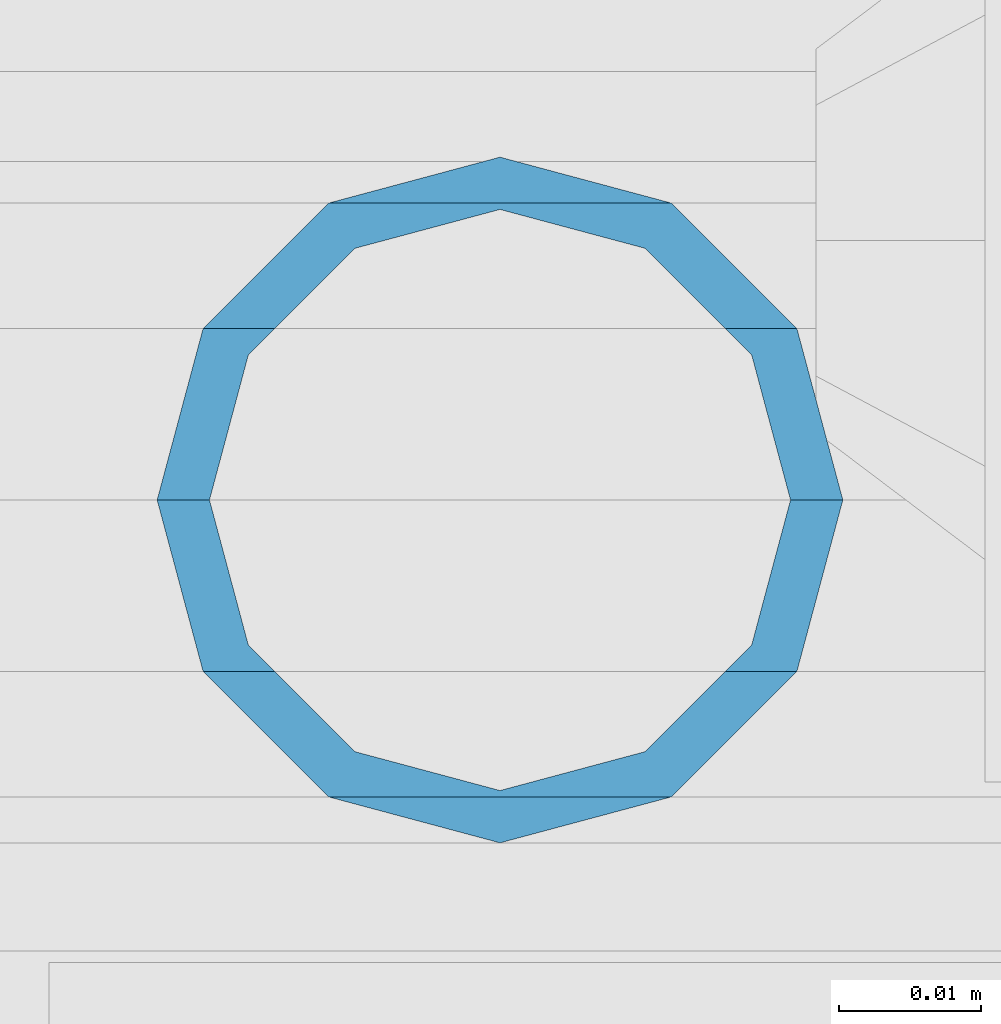
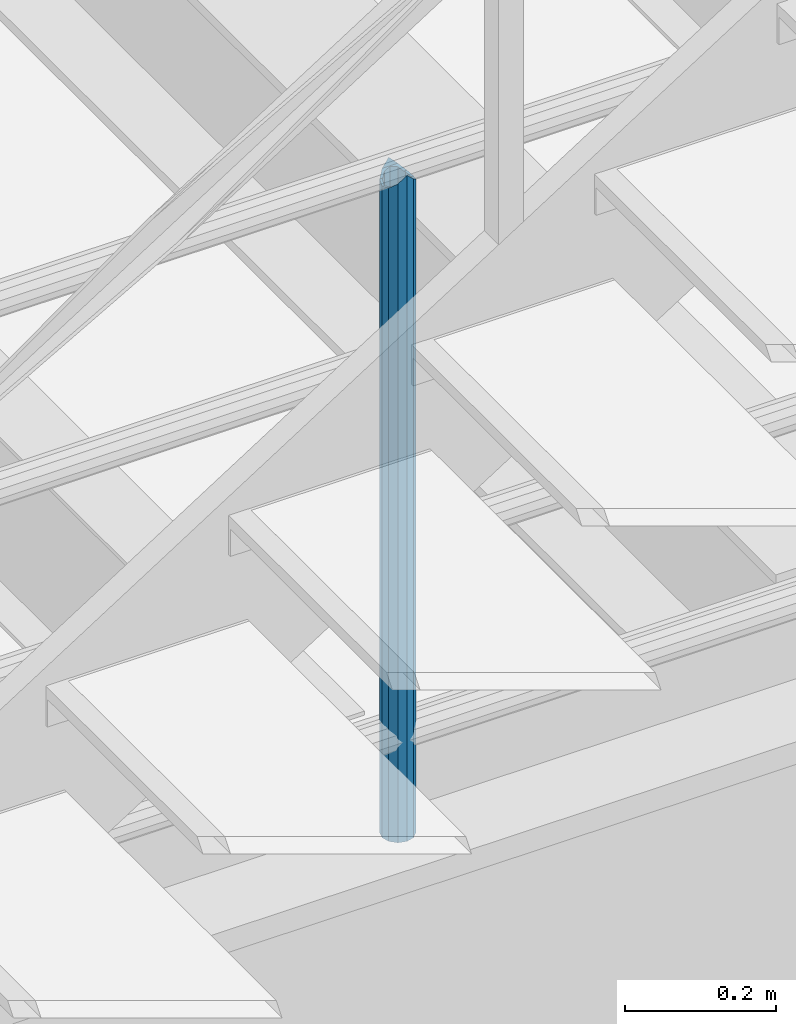
# One storey, part 614 of 1876: 1 column, 1 element without a shape of its own.
"""IFC2X3 building model written with IfcOpenShell, lengths in millimetres."""

from ifc_helpers import new_model, si_unit, frame, origin_with_axes, place, context, subcontext, project, spatial, faceted_brep, material, type_object, element, aggregate, save


model = new_model("IFC2X3")

# Units and contexts
model_context = context("Model", 3, precision=1e-05, world=origin_with_axes())
body_context = subcontext(model_context, "Body", "Model", "MODEL_VIEW")
ifc_project = project(units=[si_unit("LENGTHUNIT", "METRE", prefix="MILLI"), si_unit("AREAUNIT", "SQUARE_METRE"), si_unit("VOLUMEUNIT", "CUBIC_METRE"), si_unit("MASSUNIT", "GRAM", prefix="KILO"), si_unit("TIMEUNIT", "SECOND"), si_unit("PLANEANGLEUNIT", "RADIAN"), si_unit("SOLIDANGLEUNIT", "STERADIAN"), si_unit("THERMODYNAMICTEMPERATUREUNIT", "DEGREE_CELSIUS"), si_unit("LUMINOUSINTENSITYUNIT", "LUMEN")], contexts=[model_context])

# Site, building, storey
site_placement = place(None, origin_with_axes())
site = spatial("IfcSite", under=ifc_project, at=site_placement, CompositionType="ELEMENT")
building_placement = place(site_placement, origin_with_axes())
building = spatial("IfcBuilding", under=site, at=building_placement, Name="Undefined", CompositionType="ELEMENT")
storey_placement = place(building_placement, origin_with_axes())
storey = spatial("IfcBuildingStorey", under=building, at=storey_placement, Name="Undefined", CompositionType="ELEMENT", Elevation=0.0)

# Assembly, column
assembly_placement = place(storey_placement, origin_with_axes())
assembly = element("IfcElementAssembly", 1, at=assembly_placement, inside=storey, Name="RAIL", AssemblyPlace="NOTDEFINED", PredefinedType="RIGID_FRAME")
ifc_material = material()
column_type = type_object("IfcColumnType", Name="PIPE1-1/2SCH40", PredefinedType="NOTDEFINED")
column_placement = place(assembly_placement, frame((2806.70000023354, -4654.55000114554, 5130.8), z_axis=(1.0, 0.0, 0.0), x_axis=(0.0, 0.0, 1.0)))
column = element("IfcColumn", 2, at=column_placement, type_object=column_type, material=ifc_material, Name="POST", ObjectType="PIPE1-1/2SCH40", context=body_context, shape_type="Brep", body=[
    faceted_brep([(1055.42798316718, -12.0649999999996, 20.8971929933186), (1055.42794075525, -12.0649999993175, 15.8661214318627), (1054.93452784139, -10.2235000000001, 17.7076214311805), (1052.19517236526, 0.0, 20.4470000000001), (1052.19520341295, 0.0, 24.1300000000001), (1054.93452784103, 10.2235000000001, 17.7076214311805), (1055.42794075525, 12.0650000006817, 15.8661214304984), (1055.42798316718, 12.0649999999996, 20.8971929933186), (1076.325, 24.1300000000001, 0.0), (1064.26010170542, 20.8971929933186, 12.0650000000001), (1064.25989828953, 20.8971929933186, -12.0650000000001), (1061.07051461865, 17.7076214311801, 10.2235000000001), (1063.80980700668, 20.4469999999999, 0.0), (1061.07034225044, 17.7076214311801, -10.2235000000001), (1055.42767325244, 12.0650000006817, -15.8661214304984), (1055.42763084051, 12.0649999999996, -20.8971929933186), (1054.93422929053, 10.2235000000001, -17.7076214311805), (1052.19482762884, 0.0, -20.4470000000001), (1052.19479658115, 0.0, -24.1300000000001), (1055.42767325244, -12.0649999993175, -15.8661214318627), (1055.42763084051, -12.0649999999996, -20.8971929933186), (1054.9342292909, -10.2235000000001, -17.7076214311805), (1076.325, -24.1300000000001, 0.0), (1064.25989828953, -20.8971929933186, -12.0650000000001), (1064.26010170542, -20.8971929933186, 12.0650000000001), (1061.0703422518, -17.7076214311801, -10.2235000000001), (1063.80980700668, -20.4469999999999, 0.0), (1061.07051462001, -17.7076214311801, 10.2235000000001), (0.0, -20.8971929933184, -12.0649999999996), (0.0, -12.0650000000001, -20.8971929933186), (-1.45519152283669e-11, 0.0, -24.130000000001), (0.0, 12.0650000000001, -20.8971929933186), (0.0, 20.8971929933184, -12.0649999999996), (0.0, 24.1299999999992, 0.0), (0.0, 20.8971929933184, 12.0649999999996), (0.0, 12.0650000000001, 20.8971929933186), (-1.45519152283669e-11, 0.0, 24.130000000001), (0.0, -12.0650000000001, 20.8971929933186), (0.0, -20.8971929933184, 12.0649999999996), (0.0, -24.1299999999992, 0.0), (0.0, -17.7076214311803, -10.2235000000001), (0.0, -10.2235000000001, -17.7076214311801), (-1.45519152283669e-11, 0.0, -20.4470000000001), (0.0, 10.2235000000001, -17.7076214311801), (0.0, 17.7076214311803, -10.2235000000001), (0.0, 20.4469999999999, 0.0), (0.0, 17.7076214311803, 10.2235000000001), (0.0, 10.2235000000001, 17.7076214311801), (-1.45519152283669e-11, 0.0, 20.4470000000001), (0.0, -10.2235000000001, 17.7076214311801), (0.0, -17.7076214311803, 10.2235000000001), (0.0, -20.4469999999999, 0.0)], [[[0, 1, 2, 3, 4]], [[4, 3, 5, 6, 7]], [[8, 9, 10]], [[7, 6, 11, 12, 13, 14, 15, 10, 9]], [[16, 17, 18, 15, 14]], [[19, 20, 18, 17, 21]], [[22, 23, 24]], [[24, 23, 20, 19, 25, 26, 27, 1, 0]], [[28, 29, 20, 23]], [[29, 30, 18, 20]], [[30, 31, 15, 18]], [[31, 32, 10, 15]], [[32, 33, 8, 10]], [[33, 34, 9, 8]], [[34, 35, 7, 9]], [[35, 36, 4, 7]], [[36, 37, 0, 4]], [[37, 38, 24, 0]], [[38, 39, 22, 24]], [[39, 28, 23, 22]], [[38, 37, 36, 35, 34, 33, 32, 31, 30, 29, 28, 39], [40, 41, 42, 43, 44, 45, 46, 47, 48, 49, 50, 51]], [[40, 51, 26, 25]], [[21, 41, 40, 25, 19]], [[42, 41, 21, 17]], [[43, 42, 17, 16]], [[44, 43, 16, 14, 13]], [[45, 44, 13, 12]], [[46, 45, 12, 11]], [[5, 47, 46, 11, 6]], [[48, 47, 5, 3]], [[49, 48, 3, 2]], [[50, 49, 2, 1, 27]], [[51, 50, 27, 26]]]),
])
aggregate(assembly, [column])

save(model, "model.ifc")
